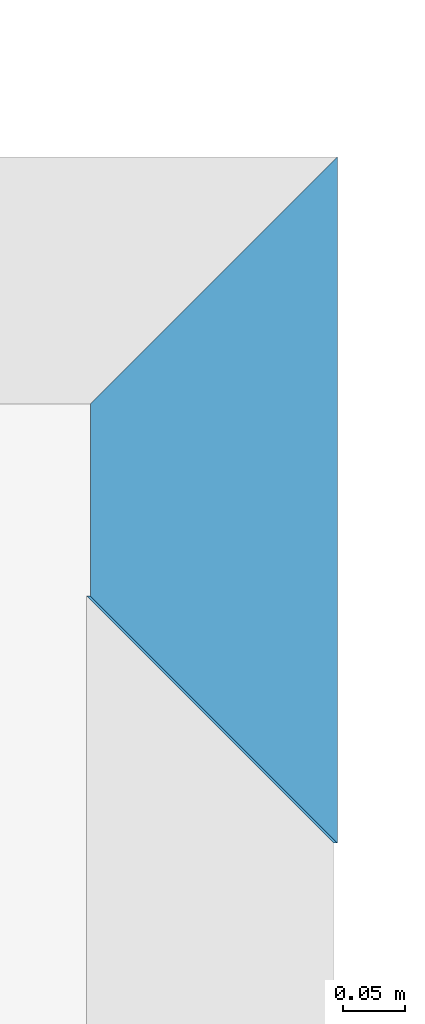
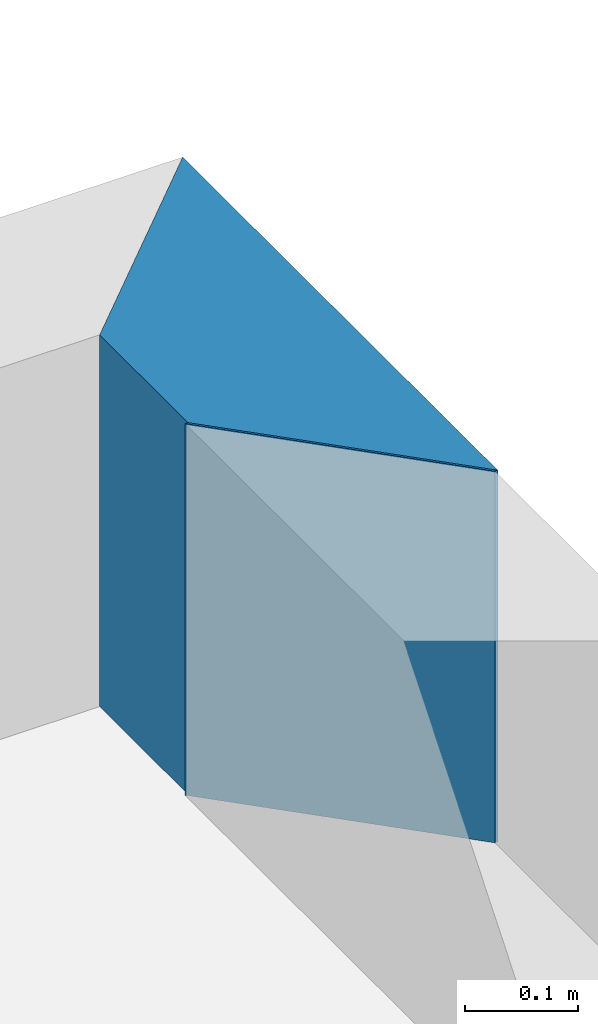
# One storey, part 11 of 72: 2 walls.
"""IFC2X3 building model written with IfcOpenShell, lengths in metres."""

from ifc_helpers import new_model, entity, si_unit, converted_unit, derived_unit, frame, origin_with_axes, place, context, project, spatial, polyline, outline, extrude, material, layer, layer_set, layer_usage, element, save


model = new_model("IFC2X3")

# Units and contexts
context_of_model_1 = context(None, 3, world=origin_with_axes())
context_of_model_2 = context(None, 3, world=origin_with_axes())
context_of_model_3 = context(None, 2, world=origin_with_axes())
context_of_model_4 = context(None, 3, world=origin_with_axes())
ifc_project = project(units=[si_unit("LENGTHUNIT", "METRE"), si_unit("AREAUNIT", "SQUARE_METRE"), si_unit("ELECTRICCURRENTUNIT", "AMPERE"), si_unit("ELECTRICVOLTAGEUNIT", "VOLT"), si_unit("ELECTRICRESISTANCEUNIT", "OHM"), si_unit("POWERUNIT", "WATT"), si_unit("MASSUNIT", "GRAM"), si_unit("SOLIDANGLEUNIT", "STERADIAN"), si_unit("THERMODYNAMICTEMPERATUREUNIT", "KELVIN"), si_unit("PRESSUREUNIT", "PASCAL"), si_unit("LUMINOUSFLUXUNIT", "LUMEN"), si_unit("ILLUMINANCEUNIT", "LUX"), si_unit("FREQUENCYUNIT", "HERTZ"), si_unit("VOLUMEUNIT", "CUBIC_METRE"), si_unit("TIMEUNIT", "SECOND"), derived_unit("VOLUMETRICFLOWRATEUNIT", [(si_unit("TIMEUNIT", "SECOND"), -1), (si_unit("VOLUMEUNIT", "CUBIC_METRE"), 1)]), derived_unit("THERMALTRANSMITTANCEUNIT", [(si_unit("AREAUNIT", "SQUARE_METRE"), -1), (si_unit("THERMODYNAMICTEMPERATUREUNIT", "KELVIN"), -1), (si_unit("POWERUNIT", "WATT"), 1)]), converted_unit("PLANEANGLEUNIT", "DEGREE", entity("IfcPlaneAngleMeasure", 57.29577951308232), si_unit("PLANEANGLEUNIT", "RADIAN"), dimensions=[0, 0, 0, 0, 0, 0, 0])], contexts=[context_of_model_1, context_of_model_2, context_of_model_3, context_of_model_4])

# Site, building, storey
site = spatial("IfcSite", under=ifc_project, CompositionType="ELEMENT")
building_placement = place(None, origin_with_axes())
building = spatial("IfcBuilding", under=site, at=building_placement, Name="200", CompositionType="ELEMENT")
storey_placement = place(building_placement, frame((0.0, 0.0, 15.68000030517578), z_axis=(0.0, 0.0, 1.0), x_axis=(1.0, 0.0, 0.0)))
storey = spatial("IfcBuildingStorey", under=building, at=storey_placement, Name="3.etasje", CompositionType="ELEMENT", Elevation=15.68000030517578)

# Walls
ifc_material = material(Name="Layer-YV04 20 cm")
ifc_layer = layer(ifc_material, 0.2000000029802322, ventilated=False)
ifc_layer_set = layer_set([ifc_layer])
ifc_layer_usage = layer_usage(ifc_layer_set, "AXIS2", "POSITIVE", 0.0)
wall_1_placement = place(storey_placement, frame((12.73623752593994, -1.873655915260315, 0.0), z_axis=(0.0, 0.0, 1.0), x_axis=(1.0, 0.0, 0.0)))
element("IfcWallStandardCase", 1, at=wall_1_placement, inside=storey, material=ifc_layer_usage, Name="YV04 20 cm", context=context_of_model_1, shape_type="SweptSolid", body=[
    extrude(outline(polyline([(0.0, 0.0), (0.00299072265625, 0.0), (-0.1970090866088867, 0.2000000476837158), (-0.1999998092651367, 0.2000006437301636), (0.0, 0.0)])), origin_with_axes(), (0.0, 0.0, 1.0), 0.4),
])
wall_2_placement = place(storey_placement, frame((12.73922824859619, -1.873655915260315, 0.0), z_axis=(0.0, 0.0, 1.0), x_axis=(-4.371138828673793e-08, 1.0, 0.0)))
element("IfcWallStandardCase", 2, at=wall_2_placement, inside=storey, material=ifc_layer_usage, Name="YV04 20 cm", context=context_of_model_1, shape_type="SweptSolid", body=[
    extrude(outline(polyline([(0.0, 0.0), (0.555649518966675, 0.0), (0.3556494712829594, 0.1999998092651368), (0.2000000476837164, 0.199999809265137), (0.0, 0.0)])), frame((0.0, 0.0, 0.0), z_axis=(0.0, 0.0, 1.0), x_axis=(0.999999999999999, -4.371138910624091e-08, 0.0)), (0.0, 0.0, 1.0), 0.4),
])

save(model, "model.ifc")
